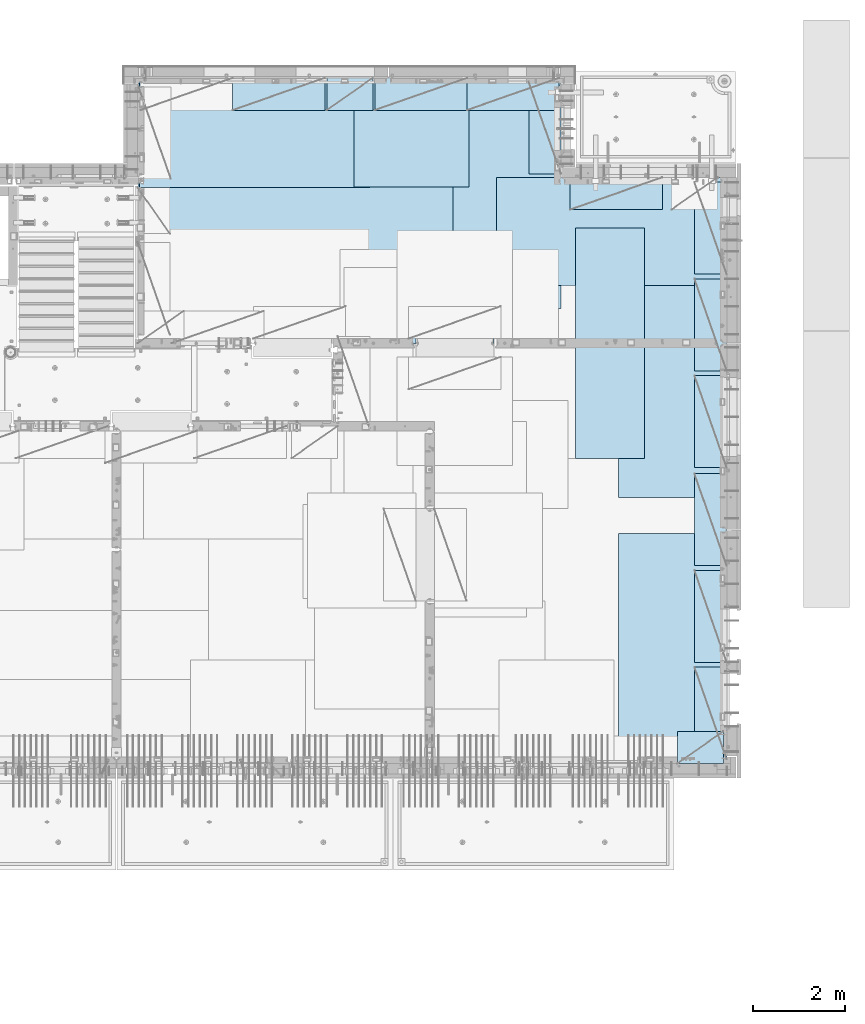
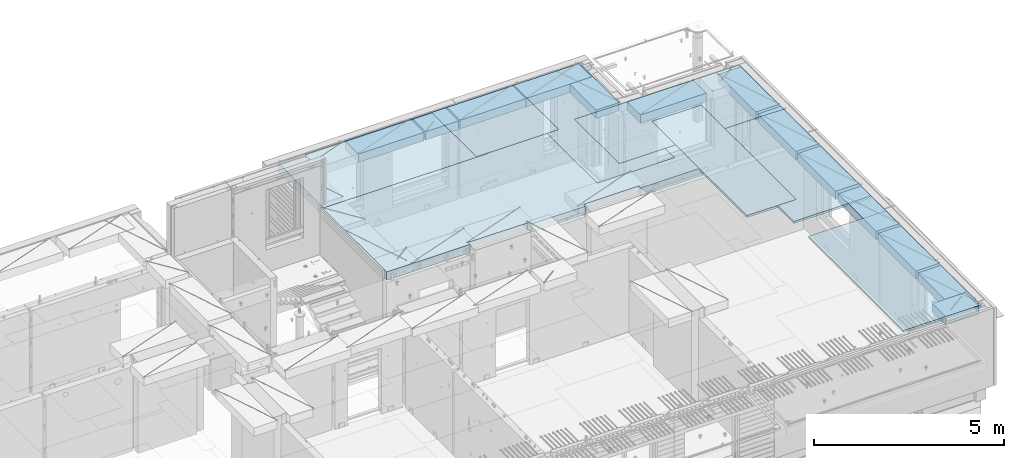
# One storey, part 190 of 325: 20 plates, 1 slab, 21 elements without a shape of their own.
"""IFC2X3 building model written with IfcOpenShell, lengths in millimetres."""

import ifcopenshell
import ifcopenshell.guid

model = None  # the IFC model being written
_history = None  # IfcOwnerHistory: only IFC2X3 demands one
_inside = {}  # id of a spatial element -> (the spatial element, [elements in it])
_under = {}  # id of a project, library or spatial element -> (it, [spatial elements below it])
_declared = {}  # id of a project -> (the project, [libraries it declares])
_typed = {}  # id of a type object -> (the type object, [elements of that type])
_made_of = {}  # id of a material, layer set ... -> (it, [elements and type objects made of it])


def new_model(schema):
    """Start an empty IFC model of exactly this schema.

    Asked for "IFC4X3", IfcOpenShell would pick the latest addendum, in which some entities
    have other attributes; the version numbers below select the first issue.
    IFC2X3 requires an IfcOwnerHistory on every rooted entity: one is made here for all.
    """
    global model, _history
    if schema == "IFC4X3":
        model = ifcopenshell.file(schema_version=(4, 3, 0, 0))
    else:
        model = ifcopenshell.file(schema=schema)
    _inside.clear()
    _under.clear()
    _declared.clear()
    _typed.clear()
    _made_of.clear()
    _history = None
    if model.schema == "IFC2X3":
        org = make("IfcOrganization", Name="unknown")
        user = make(
            "IfcPersonAndOrganization",
            ThePerson=make("IfcPerson", FamilyName="unknown"),
            TheOrganization=org,
        )
        app = make(
            "IfcApplication",
            ApplicationDeveloper=org,
            Version="unknown",
            ApplicationFullName="unknown",
            ApplicationIdentifier="unknown",
        )
        _history = make(
            "IfcOwnerHistory",
            OwningUser=user,
            OwningApplication=app,
            ChangeAction="ADDED",
            CreationDate=0,
        )
    return model


def make(cls, **values):
    """One entity of the class cls with the attributes given. An attribute that is None is left unset."""
    return model.create_entity(
        cls, **{name: value for name, value in values.items() if value is not None}
    )


def rooted(cls, **values):
    """An entity with a GlobalId (a new one), such as an element, a storey or a relation."""
    return make(cls, GlobalId=ifcopenshell.guid.new(), OwnerHistory=_history, **values)


def si_unit(unit_type, name, prefix=None):
    """IfcSIUnit, for example si_unit("LENGTHUNIT", "METRE", prefix="MILLI")."""
    return make("IfcSIUnit", UnitType=unit_type, Prefix=prefix, Name=name)


def assignment(units):
    """IfcUnitAssignment: the units of a project."""
    return None if units is None else make("IfcUnitAssignment", Units=units)


def point(xyz):
    """IfcCartesianPoint."""
    return None if xyz is None else make("IfcCartesianPoint", Coordinates=xyz)


def direction(xyz):
    """IfcDirection."""
    return None if xyz is None else make("IfcDirection", DirectionRatios=xyz)


def frame(location, z_axis=None, x_axis=None):
    """IfcAxis2Placement3D, a coordinate frame: its origin and axes. An axis left out is left unset."""
    return make(
        "IfcAxis2Placement3D",
        Location=point(location),
        Axis=direction(z_axis),
        RefDirection=direction(x_axis),
    )


def origin_with_axes():
    """The frame at (0, 0, 0) with the z axis (0, 0, 1) and the x axis (1, 0, 0) written out."""
    return frame((0.0, 0.0, 0.0), z_axis=(0.0, 0.0, 1.0), x_axis=(1.0, 0.0, 0.0))


def place(relative_to, where):
    """IfcLocalPlacement: puts the frame where relative to a parent placement (None: the world)."""
    return make(
        "IfcLocalPlacement", PlacementRelTo=relative_to, RelativePlacement=where
    )


def context(
    kind, dimensions, precision=None, world=None, true_north=None, identifier=None
):
    """IfcGeometricRepresentationContext, for example the 3D "Model" context."""
    return make(
        "IfcGeometricRepresentationContext",
        ContextIdentifier=identifier,
        ContextType=kind,
        CoordinateSpaceDimension=dimensions,
        Precision=precision,
        WorldCoordinateSystem=world,
        TrueNorth=true_north,
    )


def subcontext(parent, identifier, kind, view, scale=None):
    """IfcGeometricRepresentationSubContext, for example "Body" below "Model"."""
    return make(
        "IfcGeometricRepresentationSubContext",
        ContextIdentifier=identifier,
        ContextType=kind,
        ParentContext=parent,
        TargetScale=scale,
        TargetView=view,
    )


def project(units=None, contexts=None):
    """IfcProject with its units and contexts."""
    return rooted(
        "IfcProject",
        Name="project",
        RepresentationContexts=contexts,
        UnitsInContext=assignment(units),
    )


def spatial(cls, under=None, at=None, **own):
    """A site, building, storey or space (cls), placed at a placement, below another one or the project."""
    s = rooted(cls, ObjectPlacement=at, **own)
    if under is not None:
        _under.setdefault(under.id(), (under, []))[1].append(s)
    return s


def faces_of(points, faces, orient=None, outer=None):
    """IfcFace entities. A face is a list of loops; a loop is a list of indices into points, from 0.

    orient and outer hold one flag for each loop. By default every Orientation is true, the
    first loop of a face is its IfcFaceOuterBound and the others are IfcFaceBound.
    """
    made = []
    for i, loops in enumerate(faces):
        bounds = []
        for j, loop in enumerate(loops):
            is_outer = j == 0 if outer is None else outer[i][j]
            bounds.append(
                make(
                    "IfcFaceOuterBound" if is_outer else "IfcFaceBound",
                    Bound=make("IfcPolyLoop", Polygon=[points[k] for k in loop]),
                    Orientation=True if orient is None else orient[i][j],
                )
            )
        made.append(make("IfcFace", Bounds=bounds))
    return made


def faceted_brep(points, faces, orient=None, outer=None, voids=None):
    """IfcFacetedBrep: a solid bounded by flat faces; with voids (closed shells), ...WithVoids."""
    shared = [point(p) for p in points]
    hull = make("IfcClosedShell", CfsFaces=faces_of(shared, faces, orient, outer))
    if voids is None:
        return make("IfcFacetedBrep", Outer=hull)
    return make(
        "IfcFacetedBrepWithVoids",
        Outer=hull,
        Voids=[
            make(cls, CfsFaces=faces_of(shared, fs, o, b)) for cls, fs, o, b in voids
        ],
    )


def shape(context_of_items, identifier, shape_type, items):
    """IfcShapeRepresentation: the items that make up one representation, for example the "Body"."""
    return make(
        "IfcShapeRepresentation",
        ContextOfItems=context_of_items,
        RepresentationIdentifier=identifier,
        RepresentationType=shape_type,
        Items=items,
    )


def material(Name=None, Category=None):
    """IfcMaterial."""
    return make("IfcMaterial", Name=Name, Category=Category)


def made_of(thing, what):
    """Note that an element or type object is made of a material, layer set ...; save() writes the relation."""
    if what is not None:
        _made_of.setdefault(what.id(), (what, []))[1].append(thing)
    return thing


def type_object(cls, material=None, **own):
    """A type object (cls), such as IfcWallType, which elements share."""
    return made_of(rooted(cls, **own), material)


def element(
    cls,
    number,
    at=None,
    inside=None,
    cuts=None,
    type_object=None,
    material=None,
    context=None,
    identifier="Body",
    shape_type=None,
    held_by="IfcProductDefinitionShape",
    body=None,
    shapes=None,
    **own,
):
    """One element of the class cls, such as IfcWall. Its Tag is "e" and its number.

    at: its placement. inside: the storey or other place that contains it. cuts: it is an
    opening in that element (IfcRelVoidsElement). A single representation is given by context,
    identifier, shape_type and body (its items); several are given by shapes. held_by: the class
    of the entity that holds the representations. save() writes the other relations.
    """
    e = rooted(cls, Tag="e%d" % number, ObjectPlacement=at, **own)
    if body is not None:
        shapes = [shape(context, identifier, shape_type, body)]
    if shapes is not None:
        e.Representation = make(held_by, Representations=shapes)
    if inside is not None:
        _inside.setdefault(inside.id(), (inside, []))[1].append(e)
    if cuts is not None:
        rooted(
            "IfcRelVoidsElement", RelatingBuildingElement=cuts, RelatedOpeningElement=e
        )
    if type_object is not None:
        _typed.setdefault(type_object.id(), (type_object, []))[1].append(e)
    return made_of(e, material)


def aggregate(whole, parts):
    """IfcRelAggregates: a whole, such as a stair, and the parts it consists of."""
    return rooted("IfcRelAggregates", RelatingObject=whole, RelatedObjects=parts)


def save(model, path):
    """Write the relations noted so far, then the file.

    IfcRelAggregates (storeys below a building ...), IfcRelContainedInSpatialStructure (elements
    in a storey), IfcRelDefinesByType, IfcRelAssociatesMaterial and IfcRelDeclares: one each for
    every whole, place, type object, material and project.
    """
    for whole, parts in _under.values():
        aggregate(whole, parts)
    for where, things in _inside.values():
        rooted(
            "IfcRelContainedInSpatialStructure",
            RelatedElements=things,
            RelatingStructure=where,
        )
    for kind, things in _typed.values():
        rooted("IfcRelDefinesByType", RelatedObjects=things, RelatingType=kind)
    for what, things in _made_of.values():
        rooted("IfcRelAssociatesMaterial", RelatedObjects=things, RelatingMaterial=what)
    for by, libraries in _declared.values():
        rooted("IfcRelDeclares", RelatingContext=by, RelatedDefinitions=libraries)
    model.write(path)


model = new_model("IFC2X3")

# Units and contexts
model_context = context("Model", 3, precision=1e-05, world=origin_with_axes())
body_context = subcontext(model_context, "Body", "Model", "MODEL_VIEW")
ifc_project = project(units=[si_unit("LENGTHUNIT", "METRE", prefix="MILLI"), si_unit("AREAUNIT", "SQUARE_METRE"), si_unit("VOLUMEUNIT", "CUBIC_METRE"), si_unit("MASSUNIT", "GRAM", prefix="KILO"), si_unit("TIMEUNIT", "SECOND"), si_unit("PLANEANGLEUNIT", "RADIAN"), si_unit("SOLIDANGLEUNIT", "STERADIAN"), si_unit("THERMODYNAMICTEMPERATUREUNIT", "DEGREE_CELSIUS"), si_unit("LUMINOUSINTENSITYUNIT", "LUMEN")], contexts=[model_context])

# Site, building, storey
site_placement = place(None, origin_with_axes())
site = spatial("IfcSite", under=ifc_project, at=site_placement, CompositionType="ELEMENT")
building_placement = place(site_placement, origin_with_axes())
building = spatial("IfcBuilding", under=site, at=building_placement, CompositionType="ELEMENT")
storey_placement = place(building_placement, origin_with_axes())
storey = spatial("IfcBuildingStorey", under=building, at=storey_placement, Name="1", CompositionType="ELEMENT", Elevation=0.0)

# Assembly, slab
assembly_1_placement = place(storey_placement, origin_with_axes())
assembly_1 = element("IfcElementAssembly", 1, at=assembly_1_placement, inside=storey, AssemblyPlace="NOTDEFINED", PredefinedType="REINFORCEMENT_UNIT")
ifc_material_1 = material(Name="CONCRETE/C30/37")
slab_type = type_object("IfcSlabType", PredefinedType="NOTDEFINED")
slab_placement = place(assembly_1_placement, frame((22310.0, 16980.0, 84595.0), z_axis=(0.0, 1.0, 0.0), x_axis=(1.0, 0.0, 0.0)))
slab = element("IfcSlab", 2, at=slab_placement, type_object=slab_type, material=ifc_material_1, PredefinedType="FLOOR", context=body_context, shape_type="Brep", body=[
    faceted_brep([(4369.99914550782, -135.0, 99.9999987875526), (4369.99914550782, 135.0, 99.9999987875526), (4369.99914550782, 135.0, 0.0), (4369.99914550782, -135.0, 0.0), (4169.99914550781, -135.0, 99.9997253417969), (4169.99914550781, 135.0, 99.9997253417969), (2489.99914550781, -135.0, 0.0), (2489.99914550781, 135.0, 0.0), (2489.99914550781, 135.0, 99.9997253417969), (2489.99914550781, -135.0, 99.9997253417969), (1.81898940354586e-12, -135.0, 1.81898940354586e-12), (1.81898940354586e-12, 135.0, 1.81898940354586e-12), (-39.9985427856445, -135.0, -0.0037095642182976), (-39.9985427856445, 135.0, -0.0037095642182976), (-40.0, -135.0, 3600.00048828125), (-40.0, 135.0, 3600.00048828125), (-20.0, -135.0, 3600.0), (-20.0, 135.0, 3600.0), (-20.0, -135.0, 5760.0), (-20.0, 135.0, 5760.0), (9149.9990234375, -135.0, 5760.0), (9149.9990234375, 135.0, 5760.0), (9149.9990234375, -135.0, 3600.00073242188), (9149.9990234375, 135.0, 3600.00073242188), (12750.0, -135.0, 3599.9951171875), (12750.0, 135.0, 3599.9951171875), (12750.0, -135.0, 0.0), (12750.0, 135.0, 0.0), (7685.0006429507, -135.0, 0.0), (7685.0006429507, 135.0, 0.0), (7685.0006429507, -135.0, 99.9996630941932), (7685.0006429507, 135.0, 99.9996630941932), (5999.99954431789, -135.0, 99.9996630941932), (5999.99954431789, 135.0, 99.9996630941932), (5999.99954431789, -135.0, 0.0), (5999.99954431789, 135.0, 0.0), (2730.00000000001, 135.0, 99.9997253417969), (2730.00000000001, -135.0, 99.9997253417969)], [[[0, 1, 2, 3]], [[4, 5, 1, 0]], [[6, 7, 8, 9]], [[10, 11, 7, 6]], [[10, 12, 13, 11]], [[12, 14, 15, 13]], [[14, 16, 17, 15]], [[16, 18, 19, 17]], [[18, 20, 21, 19]], [[20, 22, 23, 21]], [[22, 24, 25, 23]], [[24, 26, 27, 25]], [[27, 26, 28, 29]], [[30, 31, 29, 28]], [[32, 33, 31, 30]], [[34, 35, 33, 32]], [[35, 34, 3, 2]], [[36, 8, 7, 11, 13, 15, 17, 19, 21, 23, 25, 27, 29, 31, 33, 35, 2, 1, 5]], [[37, 9, 8, 36, 5, 4]], [[34, 32, 30, 28, 26, 24, 22, 20, 18, 16, 14, 12, 10, 6, 9, 37, 4, 0, 3]]]),
])
aggregate(assembly_1, [slab])

# Assembly, plate
assembly_2_placement = place(storey_placement, origin_with_axes())
assembly_2 = element("IfcElementAssembly", 3, at=assembly_2_placement, inside=storey, Name="Steel Assembly", AssemblyPlace="NOTDEFINED", PredefinedType="NOTDEFINED")
ifc_material_2 = material()
plate_type_1 = type_object("IfcPlateType", PredefinedType="NOTDEFINED")
plate_1_placement = place(assembly_2_placement, frame((26960.07, 22728.45, 84695.1), z_axis=(1.0, 0.0, 0.0), x_axis=(0.0, -1.0, 0.0)))
plate_1 = element("IfcPlate", 4, at=plate_1_placement, type_object=plate_type_1, material=ifc_material_2, Name="1/2", context=body_context, shape_type="Brep", body=[
    faceted_brep([(0.0, -35.0, 0.0), (0.0, -35.0, 2500.0), (0.0, 35.0, 2500.0), (0.0, 35.0, 0.0), (2349.99951171875, -35.0, 2500.0), (2349.99951171875, 35.0, 2500.0), (2350.0, -35.0, 0.0), (2350.0, 35.0, 0.0)], [[[0, 1, 2, 3]], [[1, 4, 5, 2]], [[4, 6, 7, 5]], [[6, 0, 3, 7]], [[5, 7, 3, 2]], [[6, 4, 1, 0]]]),
])
aggregate(assembly_2, [plate_1])

assembly_3_placement = place(storey_placement, origin_with_axes())
assembly_3 = element("IfcElementAssembly", 5, at=assembly_3_placement, inside=storey, Name="Steel Assembly", AssemblyPlace="NOTDEFINED", PredefinedType="NOTDEFINED")
plate_2_placement = place(assembly_3_placement, frame((22309.9998779297, 22710.0009765625, 84695.1), z_axis=(1.0, 0.0, 0.0), x_axis=(0.0, -1.0, 0.0)))
plate_2 = element("IfcPlate", 6, at=plate_2_placement, type_object=plate_type_1, material=ifc_material_2, context=body_context, shape_type="Brep", body=[
    faceted_brep([(0.0, -35.0, 0.0), (0.0, -35.0, 5000.0), (0.0, 35.0, 5000.0), (0.0, 35.0, 0.0), (2349.99951171875, -35.0, 5000.0), (2349.99951171875, 35.0, 5000.0), (2350.0, -35.0, 0.0), (2350.0, 35.0, 0.0)], [[[0, 1, 2, 3]], [[1, 4, 5, 2]], [[4, 6, 7, 5]], [[6, 0, 3, 7]], [[5, 7, 3, 2]], [[6, 4, 1, 0]]]),
])
aggregate(assembly_3, [plate_2])

assembly_4_placement = place(storey_placement, origin_with_axes())
assembly_4 = element("IfcElementAssembly", 7, at=assembly_4_placement, inside=storey, Name="Steel Assembly", AssemblyPlace="NOTDEFINED", PredefinedType="NOTDEFINED")
plate_3_placement = place(assembly_4_placement, frame((31460.0, 22740.0, 84695.1), z_axis=(0.0, -1.0, 0.0), x_axis=(-1.0, 3.00000001838171e-08, 0.0)))
plate_3 = element("IfcPlate", 8, at=plate_3_placement, type_object=plate_type_1, material=ifc_material_2, context=body_context, shape_type="Brep", body=[
    faceted_brep([(0.0, -35.0, 0.0), (0.0, -35.0, 5000.0), (0.0, 35.0, 5000.0), (0.0, 35.0, 0.0), (2349.99951171875, -35.0, 5000.0), (2349.99951171875, 35.0, 5000.0), (2350.0, -35.0, 0.0), (2350.0, 35.0, 0.0)], [[[0, 1, 2, 3]], [[1, 4, 5, 2]], [[4, 6, 7, 5]], [[6, 0, 3, 7]], [[5, 7, 3, 2]], [[6, 4, 1, 0]]]),
])
aggregate(assembly_4, [plate_3])

assembly_5_placement = place(storey_placement, origin_with_axes())
assembly_5 = element("IfcElementAssembly", 9, at=assembly_5_placement, inside=storey, Name="Steel Assembly", AssemblyPlace="NOTDEFINED", PredefinedType="NOTDEFINED")
plate_4_placement = place(assembly_5_placement, frame((35060.0, 12850.0, 84695.1), z_axis=(0.0, -1.0, 0.0), x_axis=(-1.0, 3.00000001838171e-08, 0.0)))
plate_4 = element("IfcPlate", 10, at=plate_4_placement, type_object=plate_type_1, material=ifc_material_2, context=body_context, shape_type="Brep", body=[
    faceted_brep([(0.0, -35.0, 0.0), (0.0, -35.0, 5000.0), (0.0, 35.0, 5000.0), (0.0, 35.0, 0.0), (2349.99951171875, -35.0, 5000.0), (2349.99951171875, 35.0, 5000.0), (2350.0, -35.0, 0.0), (2350.0, 35.0, 0.0)], [[[0, 1, 2, 3]], [[1, 4, 5, 2]], [[4, 6, 7, 5]], [[6, 0, 3, 7]], [[5, 7, 3, 2]], [[6, 4, 1, 0]]]),
])
aggregate(assembly_5, [plate_4])

assembly_6_placement = place(storey_placement, origin_with_axes())
assembly_6 = element("IfcElementAssembly", 11, at=assembly_6_placement, inside=storey, Name="Steel Assembly", AssemblyPlace="NOTDEFINED", PredefinedType="NOTDEFINED")
plate_5_placement = place(assembly_6_placement, frame((35060.0, 18630.0, 84695.1), z_axis=(0.0, -1.0, 0.0), x_axis=(-1.0, 3.00000001838171e-08, 0.0)))
plate_5 = element("IfcPlate", 12, at=plate_5_placement, type_object=plate_type_1, material=ifc_material_2, context=body_context, shape_type="Brep", body=[
    faceted_brep([(0.0, -35.0, 0.0), (0.0, -35.0, 5000.0), (0.0, 35.0, 5000.0), (0.0, 35.0, 0.0), (2349.99951171875, -35.0, 5000.0), (2349.99951171875, 35.0, 5000.0), (2350.0, -35.0, 0.0), (2350.0, 35.0, 0.0)], [[[0, 1, 2, 3]], [[1, 4, 5, 2]], [[4, 6, 7, 5]], [[6, 0, 3, 7]], [[5, 7, 3, 2]], [[6, 4, 1, 0]]]),
])
aggregate(assembly_6, [plate_5])

assembly_7_placement = place(storey_placement, origin_with_axes())
assembly_7 = element("IfcElementAssembly", 13, at=assembly_7_placement, inside=storey, Name="Steel Assembly", AssemblyPlace="NOTDEFINED", PredefinedType="NOTDEFINED")
plate_6_placement = place(assembly_7_placement, frame((30060.0, 20580.0, 84695.1), z_axis=(1.0, 0.0, 0.0), x_axis=(0.0, -1.0, 0.0)))
plate_6 = element("IfcPlate", 14, at=plate_6_placement, type_object=plate_type_1, material=ifc_material_2, context=body_context, shape_type="Brep", body=[
    faceted_brep([(0.0, -35.0, 0.0), (0.0, -35.0, 5000.0), (0.0, 35.0, 5000.0), (0.0, 35.0, 0.0), (2349.99951171875, -35.0, 5000.0), (2349.99951171875, 35.0, 5000.0), (2350.0, -35.0, 0.0), (2350.0, 35.0, 0.0)], [[[0, 1, 2, 3]], [[1, 4, 5, 2]], [[4, 6, 7, 5]], [[6, 0, 3, 7]], [[5, 7, 3, 2]], [[6, 4, 1, 0]]]),
])
aggregate(assembly_7, [plate_6])

assembly_8_placement = place(storey_placement, origin_with_axes())
assembly_8 = element("IfcElementAssembly", 15, at=assembly_8_placement, inside=storey, Name="Steel Assembly", AssemblyPlace="NOTDEFINED", PredefinedType="NOTDEFINED")
plate_type_2 = type_object("IfcPlateType", PredefinedType="NOTDEFINED")
plate_7_placement = place(assembly_8_placement, frame((33275.0000122641, 19480.0, 84695.1000003815), z_axis=(0.0, -1.0, 0.0), x_axis=(-1.0, 3.00000001838171e-08, 0.0)))
plate_7 = element("IfcPlate", 16, at=plate_7_placement, type_object=plate_type_2, material=ifc_material_2, context=body_context, shape_type="Brep", body=[
    faceted_brep([(0.0, -35.0, 0.0), (0.0, -35.0, 5000.0), (0.0, 35.0, 5000.0), (0.0, 35.0, 0.0), (1499.99951171875, -35.0, 5000.0), (1499.99951171875, 35.0, 5000.0), (1500.0, -35.0, 0.0), (1500.0, 35.0, 0.0)], [[[0, 1, 2, 3]], [[1, 4, 5, 2]], [[4, 6, 7, 5]], [[6, 0, 3, 7]], [[5, 7, 3, 2]], [[6, 4, 1, 0]]]),
])
aggregate(assembly_8, [plate_7])

assembly_9_placement = place(storey_placement, origin_with_axes())
assembly_9 = element("IfcElementAssembly", 17, at=assembly_9_placement, inside=storey, Name="Steel Assembly", AssemblyPlace="NOTDEFINED", PredefinedType="NOTDEFINED")
plate_type_3 = type_object("IfcPlateType", PredefinedType="NOTDEFINED")
plate_8_placement = place(assembly_9_placement, frame((31420.0, 22740.0001220703, 84595.3), z_axis=(0.0, -1.0, 0.0), x_axis=(-1.0, 3.00000001838171e-08, 0.0)))
plate_8 = element("IfcPlate", 18, at=plate_8_placement, type_object=plate_type_3, material=ifc_material_2, Name="RE1", context=body_context, shape_type="Brep", body=[
    faceted_brep([(1.81898940354586e-12, -135.0, 1.81898940354586e-12), (0.0, -135.0, 699.999999999996), (0.0, 135.0, 699.999999999996), (1.81898940354586e-12, 135.0, 1.81898940354586e-12), (1999.99951171875, -135.0, 699.999999999993), (1999.99951171875, 135.0, 699.999999999993), (2000.0, -135.0, -3.63797880709171e-12), (2000.0, 135.0, -3.63797880709171e-12)], [[[0, 1, 2, 3]], [[1, 4, 5, 2]], [[4, 6, 7, 5]], [[6, 0, 3, 7]], [[5, 7, 3, 2]], [[6, 4, 1, 0]]]),
])
aggregate(assembly_9, [plate_8])

assembly_10_placement = place(storey_placement, origin_with_axes())
assembly_10 = element("IfcElementAssembly", 19, at=assembly_10_placement, inside=storey, Name="Steel Assembly", AssemblyPlace="NOTDEFINED", PredefinedType="NOTDEFINED")
plate_9_placement = place(assembly_10_placement, frame((33985.0, 7849.99999992931, 84595.3), z_axis=(0.0, 1.0, 0.0), x_axis=(1.0, 0.0, 0.0)))
plate_9 = element("IfcPlate", 20, at=plate_9_placement, type_object=plate_type_3, material=ifc_material_2, Name="RE1_1/2", context=body_context, shape_type="Brep", body=[
    faceted_brep([(1.81898940354586e-12, -135.0, 1.81898940354586e-12), (0.0, -135.0, 699.999999999996), (0.0, 135.0, 699.999999999996), (1.81898940354586e-12, 135.0, 1.81898940354586e-12), (999.99951171875, -135.0, 700.0), (999.99951171875, 135.0, 700.0), (1000.0, -135.0, 0.0), (1000.0, 135.0, 0.0)], [[[0, 1, 2, 3]], [[1, 4, 5, 2]], [[4, 6, 7, 5]], [[6, 0, 3, 7]], [[5, 7, 3, 2]], [[6, 4, 1, 0]]]),
])
aggregate(assembly_10, [plate_9])

assembly_11_placement = place(storey_placement, origin_with_axes())
assembly_11 = element("IfcElementAssembly", 21, at=assembly_11_placement, inside=storey, Name="Steel Assembly", AssemblyPlace="NOTDEFINED", PredefinedType="NOTDEFINED")
plate_10_placement = place(assembly_11_placement, frame((35060.0001220703, 14280.0, 84595.3), z_axis=(-1.0, 3.00000001838171e-08, 0.0), x_axis=(0.0, 1.0, 0.0)))
plate_10 = element("IfcPlate", 22, at=plate_10_placement, type_object=plate_type_3, material=ifc_material_2, Name="RE1", context=body_context, shape_type="Brep", body=[
    faceted_brep([(1.81898940354586e-12, -135.0, 1.81898940354586e-12), (0.0, -135.0, 699.999999999996), (0.0, 135.0, 699.999999999996), (1.81898940354586e-12, 135.0, 1.81898940354586e-12), (1999.99951171875, -135.0, 699.999999999993), (1999.99951171875, 135.0, 699.999999999993), (2000.0, -135.0, -3.63797880709171e-12), (2000.0, 135.0, -3.63797880709171e-12)], [[[0, 1, 2, 3]], [[1, 4, 5, 2]], [[4, 6, 7, 5]], [[6, 0, 3, 7]], [[5, 7, 3, 2]], [[6, 4, 1, 0]]]),
])
aggregate(assembly_11, [plate_10])

assembly_12_placement = place(storey_placement, origin_with_axes())
assembly_12 = element("IfcElementAssembly", 23, at=assembly_12_placement, inside=storey, Name="Steel Assembly", AssemblyPlace="NOTDEFINED", PredefinedType="NOTDEFINED")
plate_11_placement = place(assembly_12_placement, frame((35060.0001220703, 16380.0, 84595.3), z_axis=(-1.0, 3.00000001838171e-08, 0.0), x_axis=(0.0, 1.0, 0.0)))
plate_11 = element("IfcPlate", 24, at=plate_11_placement, type_object=plate_type_3, material=ifc_material_2, Name="RE1", context=body_context, shape_type="Brep", body=[
    faceted_brep([(1.81898940354586e-12, -135.0, 1.81898940354586e-12), (0.0, -135.0, 699.999999999996), (0.0, 135.0, 699.999999999996), (1.81898940354586e-12, 135.0, 1.81898940354586e-12), (1999.99951171875, -135.0, 699.999999999993), (1999.99951171875, 135.0, 699.999999999993), (2000.0, -135.0, -3.63797880709171e-12), (2000.0, 135.0, -3.63797880709171e-12)], [[[0, 1, 2, 3]], [[1, 4, 5, 2]], [[4, 6, 7, 5]], [[6, 0, 3, 7]], [[5, 7, 3, 2]], [[6, 4, 1, 0]]]),
])
aggregate(assembly_12, [plate_11])

assembly_13_placement = place(storey_placement, origin_with_axes())
assembly_13 = element("IfcElementAssembly", 25, at=assembly_13_placement, inside=storey, Name="Steel Assembly", AssemblyPlace="NOTDEFINED", PredefinedType="NOTDEFINED")
plate_12_placement = place(assembly_13_placement, frame((35060.0001220703, 18480.0, 84595.3), z_axis=(-1.0, 3.00000001838171e-08, 0.0), x_axis=(0.0, 1.0, 0.0)))
plate_12 = element("IfcPlate", 26, at=plate_12_placement, type_object=plate_type_3, material=ifc_material_2, Name="RE1", context=body_context, shape_type="Brep", body=[
    faceted_brep([(1.81898940354586e-12, -135.0, 1.81898940354586e-12), (0.0, -135.0, 699.999999999996), (0.0, 135.0, 699.999999999996), (1.81898940354586e-12, 135.0, 1.81898940354586e-12), (1999.99951171875, -135.0, 699.999999999993), (1999.99951171875, 135.0, 699.999999999993), (2000.0, -135.0, -3.63797880709171e-12), (2000.0, 135.0, -3.63797880709171e-12)], [[[0, 1, 2, 3]], [[1, 4, 5, 2]], [[4, 6, 7, 5]], [[6, 0, 3, 7]], [[5, 7, 3, 2]], [[6, 4, 1, 0]]]),
])
aggregate(assembly_13, [plate_12])

assembly_14_placement = place(storey_placement, origin_with_axes())
assembly_14 = element("IfcElementAssembly", 27, at=assembly_14_placement, inside=storey, Name="Steel Assembly", AssemblyPlace="NOTDEFINED", PredefinedType="NOTDEFINED")
plate_13_placement = place(assembly_14_placement, frame((35060.0001220703, 12150.0, 84595.3), z_axis=(-1.0, 3.00000001838171e-08, 0.0), x_axis=(0.0, 1.0, 0.0)))
plate_13 = element("IfcPlate", 28, at=plate_13_placement, type_object=plate_type_3, material=ifc_material_2, Name="RE1", context=body_context, shape_type="Brep", body=[
    faceted_brep([(1.81898940354586e-12, -135.0, 1.81898940354586e-12), (0.0, -135.0, 699.999999999996), (0.0, 135.0, 699.999999999996), (1.81898940354586e-12, 135.0, 1.81898940354586e-12), (1999.99951171875, -135.0, 699.999999999993), (1999.99951171875, 135.0, 699.999999999993), (2000.0, -135.0, -3.63797880709171e-12), (2000.0, 135.0, -3.63797880709171e-12)], [[[0, 1, 2, 3]], [[1, 4, 5, 2]], [[4, 6, 7, 5]], [[6, 0, 3, 7]], [[5, 7, 3, 2]], [[6, 4, 1, 0]]]),
])
aggregate(assembly_14, [plate_13])

assembly_15_placement = place(storey_placement, origin_with_axes())
assembly_15 = element("IfcElementAssembly", 29, at=assembly_15_placement, inside=storey, Name="Steel Assembly", AssemblyPlace="NOTDEFINED", PredefinedType="NOTDEFINED")
plate_14_placement = place(assembly_15_placement, frame((35060.0001220703, 10050.0, 84595.3), z_axis=(-1.0, 3.00000001838171e-08, 0.0), x_axis=(0.0, 1.0, 0.0)))
plate_14 = element("IfcPlate", 30, at=plate_14_placement, type_object=plate_type_3, material=ifc_material_2, Name="RE1", context=body_context, shape_type="Brep", body=[
    faceted_brep([(1.81898940354586e-12, -135.0, 1.81898940354586e-12), (0.0, -135.0, 699.999999999996), (0.0, 135.0, 699.999999999996), (1.81898940354586e-12, 135.0, 1.81898940354586e-12), (1999.99951171875, -135.0, 699.999999999993), (1999.99951171875, 135.0, 699.999999999993), (2000.0, -135.0, -3.63797880709171e-12), (2000.0, 135.0, -3.63797880709171e-12)], [[[0, 1, 2, 3]], [[1, 4, 5, 2]], [[4, 6, 7, 5]], [[6, 0, 3, 7]], [[5, 7, 3, 2]], [[6, 4, 1, 0]]]),
])
aggregate(assembly_15, [plate_14])

assembly_16_placement = place(storey_placement, origin_with_axes())
assembly_16 = element("IfcElementAssembly", 31, at=assembly_16_placement, inside=storey, Name="Steel Assembly", AssemblyPlace="NOTDEFINED", PredefinedType="NOTDEFINED")
plate_15_placement = place(assembly_16_placement, frame((35060.0001220703, 7950.0, 84595.3), z_axis=(-1.0, 3.00000001838171e-08, 0.0), x_axis=(0.0, 1.0, 0.0)))
plate_15 = element("IfcPlate", 32, at=plate_15_placement, type_object=plate_type_3, material=ifc_material_2, Name="RE1", context=body_context, shape_type="Brep", body=[
    faceted_brep([(1.81898940354586e-12, -135.0, 1.81898940354586e-12), (0.0, -135.0, 699.999999999996), (0.0, 135.0, 699.999999999996), (1.81898940354586e-12, 135.0, 1.81898940354586e-12), (1999.99951171875, -135.0, 699.999999999993), (1999.99951171875, 135.0, 699.999999999993), (2000.0, -135.0, -3.63797880709171e-12), (2000.0, 135.0, -3.63797880709171e-12)], [[[0, 1, 2, 3]], [[1, 4, 5, 2]], [[4, 6, 7, 5]], [[6, 0, 3, 7]], [[5, 7, 3, 2]], [[6, 4, 1, 0]]]),
])
aggregate(assembly_16, [plate_15])

assembly_17_placement = place(storey_placement, origin_with_axes())
assembly_17 = element("IfcElementAssembly", 33, at=assembly_17_placement, inside=storey, Name="Steel Assembly", AssemblyPlace="NOTDEFINED", PredefinedType="NOTDEFINED")
plate_16_placement = place(assembly_17_placement, frame((33660.0, 20580.0001220703, 84595.3), z_axis=(0.0, -1.0, 0.0), x_axis=(-1.0, 3.00000001838171e-08, 0.0)))
plate_16 = element("IfcPlate", 34, at=plate_16_placement, type_object=plate_type_3, material=ifc_material_2, Name="RE1", context=body_context, shape_type="Brep", body=[
    faceted_brep([(1.81898940354586e-12, -135.0, 1.81898940354586e-12), (0.0, -135.0, 699.999999999996), (0.0, 135.0, 699.999999999996), (1.81898940354586e-12, 135.0, 1.81898940354586e-12), (1999.99951171875, -135.0, 699.999999999993), (1999.99951171875, 135.0, 699.999999999993), (2000.0, -135.0, -3.63797880709171e-12), (2000.0, 135.0, -3.63797880709171e-12)], [[[0, 1, 2, 3]], [[1, 4, 5, 2]], [[4, 6, 7, 5]], [[6, 0, 3, 7]], [[5, 7, 3, 2]], [[6, 4, 1, 0]]]),
])
aggregate(assembly_17, [plate_16])

assembly_18_placement = place(storey_placement, origin_with_axes())
assembly_18 = element("IfcElementAssembly", 35, at=assembly_18_placement, inside=storey, Name="Steel Assembly", AssemblyPlace="NOTDEFINED", PredefinedType="NOTDEFINED")
plate_17_placement = place(assembly_18_placement, frame((31460.0001220703, 20660.0, 84595.3), z_axis=(-1.0, 3.00000001838171e-08, 0.0), x_axis=(0.0, 1.0, 0.0)))
plate_17 = element("IfcPlate", 36, at=plate_17_placement, type_object=plate_type_3, material=ifc_material_2, Name="RE1", context=body_context, shape_type="Brep", body=[
    faceted_brep([(1.81898940354586e-12, -135.0, 1.81898940354586e-12), (0.0, -135.0, 699.999999999996), (0.0, 135.0, 699.999999999996), (1.81898940354586e-12, 135.0, 1.81898940354586e-12), (1999.99951171875, -135.0, 699.999999999993), (1999.99951171875, 135.0, 699.999999999993), (2000.0, -135.0, -3.63797880709171e-12), (2000.0, 135.0, -3.63797880709171e-12)], [[[0, 1, 2, 3]], [[1, 4, 5, 2]], [[4, 6, 7, 5]], [[6, 0, 3, 7]], [[5, 7, 3, 2]], [[6, 4, 1, 0]]]),
])
aggregate(assembly_18, [plate_17])

assembly_19_placement = place(storey_placement, origin_with_axes())
assembly_19 = element("IfcElementAssembly", 37, at=assembly_19_placement, inside=storey, Name="Steel Assembly", AssemblyPlace="NOTDEFINED", PredefinedType="NOTDEFINED")
plate_18_placement = place(assembly_19_placement, frame((26330.0, 22740.0001220703, 84595.3), z_axis=(0.0, -1.0, 0.0), x_axis=(-1.0, 3.00000001838171e-08, 0.0)))
plate_18 = element("IfcPlate", 38, at=plate_18_placement, type_object=plate_type_3, material=ifc_material_2, Name="RE1", context=body_context, shape_type="Brep", body=[
    faceted_brep([(1.81898940354586e-12, -135.0, 1.81898940354586e-12), (0.0, -135.0, 699.999999999996), (0.0, 135.0, 699.999999999996), (1.81898940354586e-12, 135.0, 1.81898940354586e-12), (1999.99951171875, -135.0, 699.999999999993), (1999.99951171875, 135.0, 699.999999999993), (2000.0, -135.0, -3.63797880709171e-12), (2000.0, 135.0, -3.63797880709171e-12)], [[[0, 1, 2, 3]], [[1, 4, 5, 2]], [[4, 6, 7, 5]], [[6, 0, 3, 7]], [[5, 7, 3, 2]], [[6, 4, 1, 0]]]),
])
aggregate(assembly_19, [plate_18])

assembly_20_placement = place(storey_placement, origin_with_axes())
assembly_20 = element("IfcElementAssembly", 39, at=assembly_20_placement, inside=storey, Name="Steel Assembly", AssemblyPlace="NOTDEFINED", PredefinedType="NOTDEFINED")
plate_19_placement = place(assembly_20_placement, frame((29420.0, 22740.0001220703, 84595.3), z_axis=(0.0, -1.0, 0.0), x_axis=(-1.0, 3.00000001838171e-08, 0.0)))
plate_19 = element("IfcPlate", 40, at=plate_19_placement, type_object=plate_type_3, material=ifc_material_2, Name="RE1", context=body_context, shape_type="Brep", body=[
    faceted_brep([(1.81898940354586e-12, -135.0, 1.81898940354586e-12), (0.0, -135.0, 699.999999999996), (0.0, 135.0, 699.999999999996), (1.81898940354586e-12, 135.0, 1.81898940354586e-12), (1999.99951171875, -135.0, 699.999999999993), (1999.99951171875, 135.0, 699.999999999993), (2000.0, -135.0, -3.63797880709171e-12), (2000.0, 135.0, -3.63797880709171e-12)], [[[0, 1, 2, 3]], [[1, 4, 5, 2]], [[4, 6, 7, 5]], [[6, 0, 3, 7]], [[5, 7, 3, 2]], [[6, 4, 1, 0]]]),
])
aggregate(assembly_20, [plate_19])

assembly_21_placement = place(storey_placement, origin_with_axes())
assembly_21 = element("IfcElementAssembly", 41, at=assembly_21_placement, inside=storey, Name="Steel Assembly", AssemblyPlace="NOTDEFINED", PredefinedType="NOTDEFINED")
plate_20_placement = place(assembly_21_placement, frame((27375.0, 22740.0000000707, 84595.3), z_axis=(0.0, -1.0, 0.0), x_axis=(-1.0, 3.00000001838171e-08, 0.0)))
plate_20 = element("IfcPlate", 42, at=plate_20_placement, type_object=plate_type_3, material=ifc_material_2, Name="RE1_1/2", context=body_context, shape_type="Brep", body=[
    faceted_brep([(1.81898940354586e-12, -135.0, 1.81898940354586e-12), (0.0, -135.0, 699.999999999996), (0.0, 135.0, 699.999999999996), (1.81898940354586e-12, 135.0, 1.81898940354586e-12), (999.99951171875, -135.0, 700.0), (999.99951171875, 135.0, 700.0), (1000.0, -135.0, 0.0), (1000.0, 135.0, 0.0)], [[[0, 1, 2, 3]], [[1, 4, 5, 2]], [[4, 6, 7, 5]], [[6, 0, 3, 7]], [[5, 7, 3, 2]], [[6, 4, 1, 0]]]),
])
aggregate(assembly_21, [plate_20])

save(model, "model.ifc")
